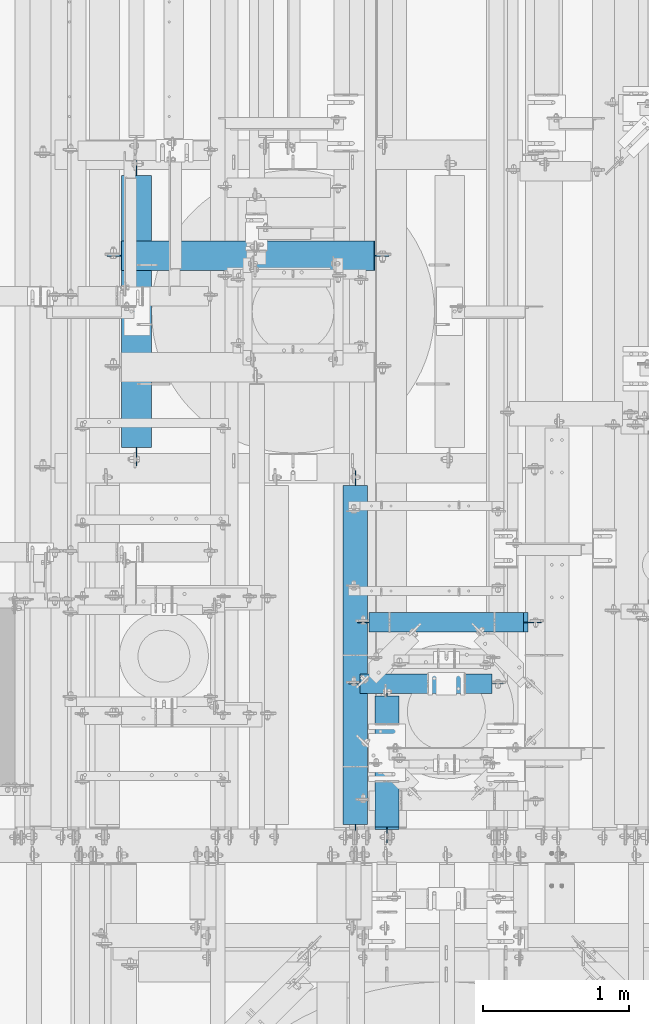
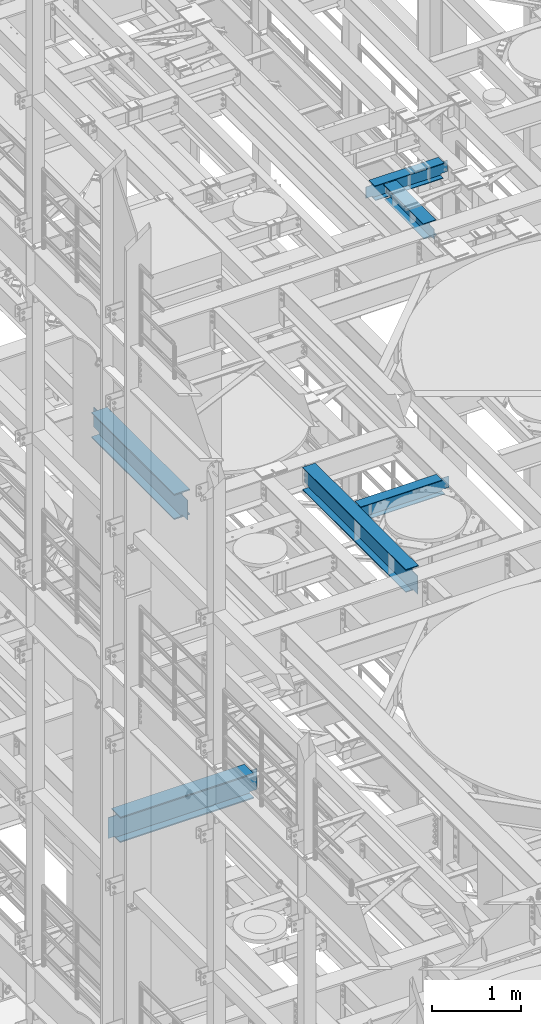
# One storey, part 1026 of 1876: 6 beams, 6 elements without a shape of their own.
"""IFC2X3 building model written with IfcOpenShell, lengths in millimetres."""

from ifc_helpers import new_model, si_unit, frame, origin_with_axes, place, context, subcontext, project, spatial, faceted_brep, material, type_object, element, aggregate, save


model = new_model("IFC2X3")

# Units and contexts
model_context = context("Model", 3, precision=1e-05, world=origin_with_axes())
body_context = subcontext(model_context, "Body", "Model", "MODEL_VIEW")
ifc_project = project(units=[si_unit("LENGTHUNIT", "METRE", prefix="MILLI"), si_unit("AREAUNIT", "SQUARE_METRE"), si_unit("VOLUMEUNIT", "CUBIC_METRE"), si_unit("MASSUNIT", "GRAM", prefix="KILO"), si_unit("TIMEUNIT", "SECOND"), si_unit("PLANEANGLEUNIT", "RADIAN"), si_unit("SOLIDANGLEUNIT", "STERADIAN"), si_unit("THERMODYNAMICTEMPERATUREUNIT", "DEGREE_CELSIUS"), si_unit("LUMINOUSINTENSITYUNIT", "LUMEN")], contexts=[model_context])

# Site, building, storey
site_placement = place(None, origin_with_axes())
site = spatial("IfcSite", under=ifc_project, at=site_placement, CompositionType="ELEMENT")
building_placement = place(site_placement, origin_with_axes())
building = spatial("IfcBuilding", under=site, at=building_placement, Name="Undefined", CompositionType="ELEMENT")
storey_placement = place(building_placement, origin_with_axes())
storey = spatial("IfcBuildingStorey", under=building, at=storey_placement, Name="Undefined", CompositionType="ELEMENT", Elevation=0.0)

# Assembly, beam
assembly_1_placement = place(storey_placement, origin_with_axes())
assembly_1 = element("IfcElementAssembly", 1, at=assembly_1_placement, inside=storey, Name="BEAM", AssemblyPlace="NOTDEFINED", PredefinedType="RIGID_FRAME")
ifc_material = material(Name="STEEL/A992")
beam_type_1 = type_object("IfcBeamType", Name="W8X24", PredefinedType="NOTDEFINED")
beam_1_placement = place(assembly_1_placement, frame((4013.20017785198, 1524.0, 17883.1875), z_axis=(0.0, 0.0, 1.0), x_axis=(0.0, 1.0, 0.0)))
beam_1 = element("IfcBeam", 2, at=beam_1_placement, type_object=beam_type_1, material=ifc_material, Name="BEAM", ObjectType="W8X24", context=body_context, shape_type="Brep", body=[
    faceted_brep([(1000.1244140625, -3.17500000000018, -90.4874999999993), (1000.1244140625, -82.5500000000002, -90.4874999820859), (1000.1244140625, -82.5500000000002, -100.012500000001), (1000.1244140625, 82.5500000000002, -100.012500000001), (1000.1244140625, 82.5500000000002, -90.4874999999993), (1000.1244140625, 3.17500000000018, -90.4874999999993), (1000.1244140625, 3.17500000000018, -87.3124998092644), (1000.1244140625, -3.17500000000018, -87.3124998092644), (1001.09114398509, 3.17500000000018, -82.452420291218), (1001.09114398509, -3.17500000000018, -82.452420291218), (1003.84415788557, 3.17500000000018, -78.3322438230643), (1003.84415788557, -3.17500000000018, -78.3322438230643), (1007.96433435372, 3.17500000000018, -75.5792299225868), (1007.96433435372, -3.17500000000018, -75.5792299225868), (1012.82441387176, 3.17500000000018, -74.6124999999993), (1012.82441387176, -3.17500000000018, -74.6124999999993), (1092.1994140625, -3.17500000000018, -74.6124999999993), (1092.1994140625, 3.17500000000018, -74.6124999999993), (127.79375, 82.5500000000002, 100.012500000001), (127.79375, -82.5500000000002, 100.012500000001), (1022.3494140625, -82.5500000000002, 100.012500000001), (1022.3494140625, 82.5500000000002, 100.012500000001), (127.79375, -82.5500000000002, 90.4874999999993), (1022.98096079099, -82.5500000000002, 90.4874999999993), (1022.3494140625, -82.5500000000002, 93.6624998092666), (1022.3494140625, 82.5500000000002, 93.6624998092666), (127.79375, 82.5500000000002, 90.4874999999993), (1022.98096079099, 82.5500000000002, 90.4874999999993), (127.79375, 3.17500000000018, 90.4874999999993), (1022.98096079099, 3.17500000000018, 90.4874999999993), (111.91875, -82.5500000000002, -90.4874998092637), (111.91875, -3.17500000000018, -90.4874999999993), (111.91875, 3.17500000000018, -90.4874999999993), (111.91875, 82.5500000000002, -90.4874999999993), (111.91875, 82.5500000000002, -100.012500000001), (111.91875, -82.5500000000002, -100.012500000001), (110.952020077412, -3.17500000000018, -85.6274202912173), (110.952020077412, 3.17500000000018, -85.6274202912173), (108.199006176934, -3.17500000000018, -81.5072438230636), (108.199006176934, 3.17500000000018, -81.5072438230636), (104.07882970878, -3.17500000000018, -78.7542299225861), (104.07882970878, 3.17500000000018, -78.7542299225861), (99.2187501907349, -3.17500000000018, -77.7874999999985), (99.2187501907349, 3.17500000000018, -77.7874999999985), (19.8437500000002, -3.17500000000018, -77.7874999999985), (19.8437500000002, 3.17500000000018, -77.7874999999985), (19.8437500000002, -3.17500000000018, 61.9125000000058), (19.8437500000002, 3.17500000000018, 61.9125000000058), (115.093750190735, -3.17500000000018, 61.9125000000058), (115.093750190735, 3.17500000000018, 61.9125000000058), (119.95382970878, -3.17500000000018, 62.8792299225934), (119.95382970878, 3.17500000000018, 62.8792299225934), (124.074006176934, -3.17500000000018, 65.6322438230709), (124.074006176934, 3.17500000000018, 65.6322438230709), (126.827020077412, -3.17500000000018, 69.7524202912246), (126.827020077412, 3.17500000000018, 69.7524202912246), (127.79375, -3.17500000000018, 74.612499809271), (127.79375, 3.17500000000018, 74.612499809271), (127.79375, -3.17500000000018, 90.4874999999993), (1022.98096079099, -3.17500000000018, 90.4874999999993), (1023.31614398509, -3.17500000000018, 88.8024202912202), (1023.31614398509, 3.17500000000018, 88.8024202912202), (1026.06915788557, -3.17500000000018, 84.6822438230665), (1026.06915788557, 3.17500000000018, 84.6822438230665), (1030.18933435372, -3.17500000000018, 81.929229922589), (1030.18933435372, 3.17500000000018, 81.929229922589), (1035.04941387176, -3.17500000000018, 80.9625000000015), (1035.04941387176, 3.17500000000018, 80.9625000000015), (1092.1994140625, -3.17500000000018, 80.9625000000015), (1092.1994140625, 3.17500000000018, 80.9625000000015)], [[[0, 1, 2, 3, 4, 5, 6, 7]], [[7, 6, 8, 9]], [[9, 8, 10, 11]], [[11, 10, 12, 13]], [[13, 12, 14, 15]], [[16, 15, 14, 17]], [[18, 19, 20, 21]], [[20, 19, 22, 23, 24]], [[20, 24, 25, 21]], [[26, 18, 21, 25, 27]], [[28, 26, 27, 29]], [[30, 31, 32, 33, 34, 35]], [[36, 37, 32, 31]], [[38, 39, 37, 36]], [[40, 41, 39, 38]], [[42, 43, 41, 40]], [[44, 45, 43, 42]], [[46, 47, 45, 44]], [[48, 49, 47, 46]], [[50, 51, 49, 48]], [[52, 53, 51, 50]], [[54, 55, 53, 52]], [[56, 57, 55, 54]], [[19, 18, 26, 28, 57, 56, 58, 22]], [[22, 58, 59, 23]], [[60, 61, 29, 27, 25, 24, 23, 59]], [[62, 63, 61, 60]], [[64, 65, 63, 62]], [[66, 67, 65, 64]], [[68, 69, 67, 66]], [[69, 68, 16, 17]], [[12, 10, 8, 6, 5, 32, 37, 39, 41, 43, 45, 47, 49, 51, 53, 55, 57, 28, 29, 61, 63, 65, 67, 69, 17, 14]], [[33, 32, 5, 4]], [[34, 33, 4, 3]], [[35, 34, 3, 2]], [[30, 35, 2, 1]], [[31, 30, 1, 0]], [[68, 66, 64, 62, 60, 59, 58, 56, 54, 52, 50, 48, 46, 44, 42, 40, 38, 36, 31, 0, 7, 9, 11, 13, 15, 16]]]),
])
aggregate(assembly_1, [beam_1])

assembly_2_placement = place(storey_placement, origin_with_axes())
assembly_2 = element("IfcElementAssembly", 3, at=assembly_2_placement, inside=storey, Name="BEAM", AssemblyPlace="NOTDEFINED", PredefinedType="RIGID_FRAME")
beam_type_2 = type_object("IfcBeamType", Name="W8X18", PredefinedType="NOTDEFINED")
beam_2_placement = place(assembly_2_placement, frame((3733.8, 2632.0744140625, 17880.0125), z_axis=(0.0, 0.0, 1.0), x_axis=(1.0, 0.0, 0.0)))
beam_2 = element("IfcBeam", 4, at=beam_2_placement, type_object=beam_type_2, material=ifc_material, Name="BEAM", ObjectType="W8X18", context=body_context, shape_type="Brep", body=[
    faceted_brep([(984.250000000001, -3.17500000000018, -95.25), (984.250000000001, -66.6750000000002, -95.25), (984.250000000001, -66.6750000000002, -103.1875), (984.250000000001, 66.6750000000002, -103.1875), (984.250000000001, 66.6750000000002, -95.25), (984.250000000001, 3.17500000000018, -95.25), (984.250000000001, 3.17500000000018, -90.4874998092637), (984.250000000001, -3.17500000000018, -90.4874998092637), (985.216729922588, 3.17500000000018, -85.6274202912173), (985.216729922588, -3.17500000000018, -85.6274202912173), (987.969743823067, 3.17500000000018, -81.5072438230636), (987.969743823067, -3.17500000000018, -81.5072438230636), (992.089920291221, 3.17500000000018, -78.7542299225861), (992.089920291221, -3.17500000000018, -78.7542299225861), (996.949999809266, 3.17500000000018, -77.7874999999985), (996.949999809266, -3.17500000000018, -77.7874999999985), (1076.325, -3.17500000000018, -77.7874999999985), (1076.325, 3.17500000000018, -77.7874999999985), (95.25, 3.17500000000018, 95.25), (95.25, 66.6750000000002, 95.25), (996.950000000001, 66.6750000000002, 95.25), (996.950000000001, 3.17500000000018, 95.25), (107.950000000001, -3.17500000000018, -90.48749980926), (107.950000000001, 3.17500000000018, -90.48749980926), (107.950000000001, 3.17500000000018, -95.25), (107.950000000001, 66.6750000000002, -95.25), (107.950000000001, 66.6750000000002, -103.1875), (107.950000000001, -66.6750000000002, -103.1875), (107.950000000001, -66.6750000000002, -95.25), (107.950000000001, -3.17500000000018, -95.25), (106.983270077413, -3.17500000000018, -85.6274202912136), (106.983270077413, 3.17500000000018, -85.6274202912136), (104.230256176935, -3.17500000000018, -81.50724382306), (104.230256176935, 3.17500000000018, -81.50724382306), (100.110079708781, -3.17500000000018, -78.7542299225825), (100.110079708781, 3.17500000000018, -78.7542299225825), (95.2500001907356, -3.17500000000018, -77.7874999999949), (95.2500001907356, 3.17500000000018, -77.7874999999949), (15.875, -3.17500000000018, -77.7874999999949), (15.875, 3.17500000000018, -77.7874999999949), (15.875, -3.17500000000018, 77.7874999999949), (15.875, 3.17500000000018, 77.7874999999949), (82.5500001907349, -3.17500000000018, 77.7874999999949), (82.5500001907349, 3.17500000000018, 77.7874999999949), (87.4100797087804, -3.17500000000018, 78.7542299225825), (87.4100797087804, 3.17500000000018, 78.7542299225825), (91.530256176934, -3.17500000000018, 81.50724382306), (91.530256176934, 3.17500000000018, 81.50724382306), (94.2832700774125, -3.17500000000018, 85.6274202912136), (94.2832700774125, 3.17500000000018, 85.6274202912136), (95.25, -3.17500000000018, 90.48749980926), (95.25, 3.17500000000018, 90.48749980926), (95.25, -66.6750000000002, 103.1875), (95.25, 66.6750000000002, 103.1875), (95.25, -3.17500000000018, 95.25), (95.25, -66.6750000000002, 95.25), (996.950000000001, -3.17500000000018, 95.25), (996.950000000001, -66.6750000000002, 95.25), (996.950000000001, -66.6750000000002, 103.1875), (996.950000000001, 66.6750000000002, 103.1875), (996.950000000001, -3.17500000000018, 90.4874998092637), (996.950000000001, 3.17500000000018, 90.4874998092637), (997.916729922588, -3.17500000000018, 85.6274202912173), (997.916729922588, 3.17500000000018, 85.6274202912173), (1000.66974382307, -3.17500000000018, 81.5072438230636), (1000.66974382307, 3.17500000000018, 81.5072438230636), (1004.78992029122, -3.17500000000018, 78.7542299225861), (1004.78992029122, 3.17500000000018, 78.7542299225861), (1009.64999980927, -3.17500000000018, 77.7874999999985), (1009.64999980927, 3.17500000000018, 77.7874999999985), (1076.325, -3.17500000000018, 77.7874999999985), (1076.325, 3.17500000000018, 77.7874999999985)], [[[0, 1, 2, 3, 4, 5, 6, 7]], [[7, 6, 8, 9]], [[9, 8, 10, 11]], [[11, 10, 12, 13]], [[13, 12, 14, 15]], [[16, 15, 14, 17]], [[18, 19, 20, 21]], [[22, 23, 24, 25, 26, 27, 28, 29]], [[30, 31, 23, 22]], [[32, 33, 31, 30]], [[34, 35, 33, 32]], [[36, 37, 35, 34]], [[38, 39, 37, 36]], [[40, 41, 39, 38]], [[42, 43, 41, 40]], [[44, 45, 43, 42]], [[46, 47, 45, 44]], [[48, 49, 47, 46]], [[50, 51, 49, 48]], [[52, 53, 19, 18, 51, 50, 54, 55]], [[55, 54, 56, 57]], [[52, 55, 57, 58]], [[53, 52, 58, 59]], [[19, 53, 59, 20]], [[58, 57, 56, 60, 61, 21, 20, 59]], [[62, 63, 61, 60]], [[64, 65, 63, 62]], [[66, 67, 65, 64]], [[68, 69, 67, 66]], [[70, 71, 69, 68]], [[71, 70, 16, 17]], [[12, 10, 8, 6, 5, 24, 23, 31, 33, 35, 37, 39, 41, 43, 45, 47, 49, 51, 18, 21, 61, 63, 65, 67, 69, 71, 17, 14]], [[25, 24, 5, 4]], [[26, 25, 4, 3]], [[27, 26, 3, 2]], [[28, 27, 2, 1]], [[29, 28, 1, 0]], [[70, 68, 66, 64, 62, 60, 56, 54, 50, 48, 46, 44, 42, 40, 38, 36, 34, 32, 30, 22, 29, 0, 7, 9, 11, 13, 15, 16]]]),
])
aggregate(assembly_2, [beam_2])

assembly_3_placement = place(storey_placement, origin_with_axes())
assembly_3 = element("IfcElementAssembly", 5, at=assembly_3_placement, inside=storey, Name="BEAM", AssemblyPlace="NOTDEFINED", PredefinedType="RIGID_FRAME")
beam_3_placement = place(assembly_3_placement, frame((3892.55, 3051.175, 13206.4125), z_axis=(0.0, 0.0, 1.0), x_axis=(1.0, 0.0, 0.0)))
beam_3 = element("IfcBeam", 6, at=beam_3_placement, type_object=beam_type_2, material=ifc_material, Name="BEAM", ObjectType="W8X18", context=body_context, shape_type="Brep", body=[
    faceted_brep([(-79.3750000000005, -3.17500000000018, -77.7875000000004), (-79.3750000000005, 3.17500000000018, -77.7875000000004), (-3.17499980926459, 3.17500000000018, -77.7875000000004), (-3.17499980926459, -3.17500000000018, -77.7875000000004), (1.6850797087809, 3.17500000000018, -78.7542299225879), (1.6850797087809, -3.17500000000018, -78.7542299225879), (5.80525617693456, 3.17500000000018, -81.5072438230654), (5.80525617693456, -3.17500000000018, -81.5072438230654), (8.55827007741254, 3.17500000000018, -85.6274202912191), (8.55827007741254, -3.17500000000018, -85.6274202912191), (9.52500000000055, -3.17500000000018, -90.4874998092655), (9.52500000000055, 3.17500000000018, -90.4874998092655), (9.52500000000055, 3.17500000000018, -95.25), (9.52500000000055, 66.6750000000002, -95.25), (9.52500000000055, 66.6750000000002, -103.1875), (9.52500000000055, -66.6750000000002, -103.1875), (9.52500000000055, -66.6750000000002, -95.25), (9.52500000000055, -3.17500000000018, -95.25), (4.54747350886464e-13, 3.17500000000018, 95.25), (4.54747350886464e-13, 66.6750000000002, 95.25), (1054.89375, 66.6750000000002, 95.25), (1054.89375, 3.17500000000018, 95.25), (-12.6999998092647, -3.17500000000018, 77.7875000000004), (-12.6999998092647, 3.17500000000018, 77.7875000000004), (-79.3750000000005, 3.17500000000018, 77.7875000000004), (-79.3750000000005, -3.17500000000018, 77.7875000000004), (-7.83992029121919, -3.17500000000018, 78.7542299225879), (-7.83992029121919, 3.17500000000018, 78.7542299225879), (-3.71974382306553, -3.17500000000018, 81.5072438230654), (-3.71974382306553, 3.17500000000018, 81.5072438230654), (-0.966729922587547, -3.17500000000018, 85.6274202912191), (-0.966729922587547, 3.17500000000018, 85.6274202912191), (4.54747350886464e-13, -3.17500000000018, 90.4874998092655), (4.54747350886464e-13, 3.17500000000018, 90.4874998092655), (4.54747350886464e-13, -66.6750000000002, 103.1875), (4.54747350886464e-13, 66.6750000000002, 103.1875), (4.54747350886464e-13, -3.17500000000018, 95.25), (4.54747350886464e-13, -66.6750000000002, 95.25), (1054.89375, -3.17500000000018, 95.25), (1054.89375, -66.6750000000002, 95.25), (1054.89375, -66.6750000000002, 103.1875), (1054.89375, 66.6750000000002, 103.1875), (1054.89375, -3.17500000000018, 90.4874998092637), (1054.89375, 3.17500000000018, 90.4874998092637), (1055.86047992259, -3.17500000000018, 85.6274202912173), (1055.86047992259, 3.17500000000018, 85.6274202912173), (1058.61349382307, -3.17500000000018, 81.5072438230636), (1058.61349382307, 3.17500000000018, 81.5072438230636), (1062.73367029122, -3.17500000000018, 78.7542299225861), (1062.73367029122, 3.17500000000018, 78.7542299225861), (1067.59374980927, -3.17500000000018, 77.7874999999985), (1067.59374980927, 3.17500000000018, 77.7874999999985), (1175.54375, -3.17500000000018, 77.7874999999985), (1175.54375, 3.17500000000018, 77.7874999999985), (1175.54375, -3.17500000000018, -77.7875000000022), (1175.54375, 3.17500000000018, -77.7875000000022), (1099.34374980927, -3.17500000000018, -77.7875000000022), (1099.34374980927, 3.17500000000018, -77.7875000000022), (1094.48367029122, -3.17500000000018, -78.7542299225897), (1094.48367029122, 3.17500000000018, -78.7542299225897), (1090.36349382307, -3.17500000000018, -81.5072438230673), (1090.36349382307, 3.17500000000018, -81.5072438230673), (1087.61047992259, -3.17500000000018, -85.6274202912209), (1087.61047992259, 3.17500000000018, -85.6274202912209), (1086.64375, -3.17500000000018, -90.4874998092673), (1086.64375, 3.17500000000018, -90.4874998092673), (1086.64375, -3.17500000000018, -95.25), (1086.64375, -66.6750000000002, -95.25), (1086.64375, -66.6750000000002, -103.1875), (1086.64375, 66.6750000000002, -103.1875), (1086.64375, 66.6750000000002, -95.25), (1086.64375, 3.17500000000018, -95.25)], [[[0, 1, 2, 3]], [[3, 2, 4, 5]], [[5, 4, 6, 7]], [[7, 6, 8, 9]], [[10, 11, 12, 13, 14, 15, 16, 17]], [[9, 8, 11, 10]], [[18, 19, 20, 21]], [[22, 23, 24, 25]], [[26, 27, 23, 22]], [[28, 29, 27, 26]], [[30, 31, 29, 28]], [[32, 33, 31, 30]], [[34, 35, 19, 18, 33, 32, 36, 37]], [[37, 36, 38, 39]], [[34, 37, 39, 40]], [[35, 34, 40, 41]], [[19, 35, 41, 20]], [[40, 39, 38, 42, 43, 21, 20, 41]], [[44, 45, 43, 42]], [[46, 47, 45, 44]], [[48, 49, 47, 46]], [[50, 51, 49, 48]], [[52, 53, 51, 50]], [[53, 52, 54, 55]], [[54, 56, 57, 55]], [[58, 59, 57, 56]], [[60, 61, 59, 58]], [[62, 63, 61, 60]], [[64, 65, 63, 62]], [[66, 67, 68, 69, 70, 71, 65, 64]], [[67, 66, 17, 16]], [[68, 67, 16, 15]], [[69, 68, 15, 14]], [[70, 69, 14, 13]], [[71, 70, 13, 12]], [[6, 4, 2, 1, 24, 23, 27, 29, 31, 33, 18, 21, 43, 45, 47, 49, 51, 53, 55, 57, 59, 61, 63, 65, 71, 12, 11, 8]], [[25, 24, 1, 0]], [[66, 64, 62, 60, 58, 56, 54, 52, 50, 48, 46, 44, 42, 38, 36, 32, 30, 28, 26, 22, 25, 0, 3, 5, 7, 9, 10, 17]]]),
])
aggregate(assembly_3, [beam_3])

assembly_4_placement = place(storey_placement, origin_with_axes())
assembly_4 = element("IfcElementAssembly", 7, at=assembly_4_placement, inside=storey, Name="BEAM", AssemblyPlace="NOTDEFINED", PredefinedType="RIGID_FRAME")
beam_type_3 = type_object("IfcBeamType", Name="W12X30", PredefinedType="NOTDEFINED")
beam_4_placement = place(assembly_4_placement, frame((3797.3, 1524.0, 13152.4375), z_axis=(0.0, 0.0, 1.0), x_axis=(0.0, 1.0, 0.0)))
beam_4 = element("IfcBeam", 8, at=beam_4_placement, type_object=beam_type_3, material=ifc_material, Name="BEAM", ObjectType="W12X30", context=body_context, shape_type="Brep", body=[
    faceted_brep([(19.8437500000002, -3.17500000000018, -131.762499999993), (19.8437500000002, 3.17500000000018, -131.762499999993), (134.143750190735, 3.17500000000018, -131.762500000001), (134.143750190735, -3.17500000000018, -131.762500000001), (139.00382970878, 3.17500000000018, -132.729229922588), (139.00382970878, -3.17500000000018, -132.729229922588), (143.124006176934, 3.17500000000018, -135.482243823066), (143.124006176934, -3.17500000000018, -135.482243823066), (145.877020077412, 3.17500000000018, -139.602420291219), (145.877020077412, -3.17500000000018, -139.602420291219), (146.84375, -3.17500000000018, -144.462499809266), (146.84375, 3.17500000000018, -144.462499809266), (146.84375, 3.17500000000018, -146.049999999999), (146.84375, 82.5500000000002, -146.049999999999), (146.84375, 82.5500000000002, -157.1625), (146.84375, -82.5500000000002, -157.1625), (146.84375, -82.5500000000002, -146.049999999999), (146.84375, -3.17500000000018, -146.049999999999), (2461.41875, 82.5500000000002, 146.049999999999), (2461.41875, 3.17500000000018, 146.049999999999), (146.84375, 3.17500000000018, 146.049999999999), (146.84375, 82.5500000000002, 146.049999999999), (134.143750190735, -3.17500000000018, 119.0625), (134.143750190735, 3.17500000000018, 119.0625), (19.8437491105051, 3.17499999999995, 119.062500000004), (19.8437491105051, -3.17499999999995, 119.062500000004), (139.00382970878, -3.17500000000018, 120.029229922588), (139.00382970878, 3.17500000000018, 120.029229922588), (143.124006176934, -3.17500000000018, 122.782243823065), (143.124006176934, 3.17500000000018, 122.782243823065), (145.877020077412, -3.17500000000018, 126.902420291219), (145.877020077412, 3.17500000000018, 126.902420291219), (146.84375, -3.17500000000018, 131.762499809265), (146.84375, 3.17500000000018, 131.762499809265), (2461.41875, -82.5500000000002, 157.1625), (2461.41875, 82.5500000000002, 157.1625), (146.84375, 82.5500000000002, 157.1625), (146.84375, -82.5500000000002, 157.1625), (2461.41875, -82.5500000000002, 146.049999999999), (146.84375, -82.5500000000002, 146.049999999999), (2461.41875, -3.17500000000018, 146.049999999999), (146.84375, -3.17500000000018, 146.049999999999), (2461.41875, -3.17500000000018, 131.762499809265), (2461.41875, 3.17500000000018, 131.762499809265), (2462.38547992259, -3.17500000000018, 126.902420291219), (2462.38547992259, 3.17500000000018, 126.902420291219), (2465.13849382307, -3.17500000000018, 122.782243823065), (2465.13849382307, 3.17500000000018, 122.782243823065), (2469.25867029122, -3.17500000000018, 120.029229922588), (2469.25867029122, 3.17500000000018, 120.029229922588), (2474.11874980927, -3.17500000000018, 119.0625), (2474.11874980927, 3.17500000000018, 119.0625), (2563.01875, -3.17500000000018, 119.0625), (2563.01875, 3.17500000000018, 119.0625), (2563.01875, -3.17500000000018, -131.762500000001), (2563.01875, 3.17500000000018, -131.762500000001), (2474.11874980927, -3.17500000000018, -131.762500000001), (2474.11874980927, 3.17500000000018, -131.762500000001), (2469.25867029122, -3.17500000000018, -132.729229922588), (2469.25867029122, 3.17500000000018, -132.729229922588), (2465.13849382307, -3.17500000000018, -135.482243823066), (2465.13849382307, 3.17500000000018, -135.482243823066), (2462.38547992259, -3.17500000000018, -139.602420291219), (2462.38547992259, 3.17500000000018, -139.602420291219), (2461.41875, -3.17500000000018, -144.462499809266), (2461.41875, 3.17500000000018, -144.462499809266), (2461.41875, -3.17500000000018, -146.049999999999), (2461.41875, -82.5500000000002, -146.049999999999), (2461.41875, -82.5500000000002, -157.1625), (2461.41875, 82.5500000000002, -157.1625), (2461.41875, 82.5500000000002, -146.049999999999), (2461.41875, 3.17500000000018, -146.049999999999)], [[[0, 1, 2, 3]], [[3, 2, 4, 5]], [[5, 4, 6, 7]], [[7, 6, 8, 9]], [[10, 11, 12, 13, 14, 15, 16, 17]], [[9, 8, 11, 10]], [[18, 19, 20, 21]], [[22, 23, 24, 25]], [[26, 27, 23, 22]], [[28, 29, 27, 26]], [[30, 31, 29, 28]], [[32, 33, 31, 30]], [[34, 35, 36, 37]], [[38, 34, 37, 39]], [[40, 38, 39, 41]], [[37, 36, 21, 20, 33, 32, 41, 39]], [[35, 18, 21, 36]], [[34, 38, 40, 42, 43, 19, 18, 35]], [[44, 45, 43, 42]], [[46, 47, 45, 44]], [[48, 49, 47, 46]], [[50, 51, 49, 48]], [[52, 53, 51, 50]], [[53, 52, 54, 55]], [[54, 56, 57, 55]], [[58, 59, 57, 56]], [[60, 61, 59, 58]], [[62, 63, 61, 60]], [[64, 65, 63, 62]], [[66, 67, 68, 69, 70, 71, 65, 64]], [[67, 66, 17, 16]], [[68, 67, 16, 15]], [[69, 68, 15, 14]], [[70, 69, 14, 13]], [[71, 70, 13, 12]], [[6, 4, 2, 1, 24, 23, 27, 29, 31, 33, 20, 19, 43, 45, 47, 49, 51, 53, 55, 57, 59, 61, 63, 65, 71, 12, 11, 8]], [[25, 24, 1, 0]], [[66, 64, 62, 60, 58, 56, 54, 52, 50, 48, 46, 44, 42, 40, 41, 32, 30, 28, 26, 22, 25, 0, 3, 5, 7, 9, 10, 17]]]),
])
aggregate(assembly_4, [beam_4])

assembly_5_placement = place(storey_placement, origin_with_axes())
assembly_5 = element("IfcElementAssembly", 9, at=assembly_5_placement, inside=storey, Name="BEAM", AssemblyPlace="NOTDEFINED", PredefinedType="RIGID_FRAME")
beam_type_4 = type_object("IfcBeamType", Name="W14X48", PredefinedType="NOTDEFINED")
beam_5_placement = place(assembly_5_placement, frame((2301.875, 4057.65, 13134.975), z_axis=(0.0, 0.0, 1.0), x_axis=(0.0, 1.0, 0.0)))
beam_5 = element("IfcBeam", 10, at=beam_5_placement, type_object=beam_type_4, material=ifc_material, Name="BEAM", ObjectType="W14X48", context=body_context, shape_type="Brep", body=[
    faceted_brep([(62.7062500000002, -3.96875, -136.525), (62.7062500000002, 3.96875, -136.525), (177.006250190735, 3.96875, -136.525), (177.006250190735, -3.96875, -136.525), (181.866329708781, 3.96875, -137.491729922587), (181.866329708781, -3.96875, -137.491729922587), (185.986506176934, 3.96875, -140.244743823065), (185.986506176934, -3.96875, -140.244743823065), (188.739520077413, 3.96875, -144.364920291218), (188.739520077413, -3.96875, -144.364920291218), (189.70625, -3.96875, -149.224999809265), (189.70625, 3.96875, -149.224999809265), (189.70625, 3.96875, -158.75), (189.70625, 101.6, -158.75), (189.70625, 101.6, -174.625), (189.70625, -101.6, -174.625), (189.70625, -101.6, -158.75), (189.70625, -3.96875, -158.75), (189.70625, 3.96875, 158.75), (189.70625, 101.6, 158.75), (2045.49375, 101.6, 158.75), (2045.49375, 3.96875, 158.75), (177.006250190735, -3.96875, 136.525), (177.006250190735, 3.96875, 136.525), (62.7062500000002, 3.96875, 136.525), (62.7062500000002, -3.96875, 136.525), (181.866329708781, -3.96875, 137.491729922587), (181.866329708781, 3.96875, 137.491729922587), (185.986506176934, -3.96875, 140.244743823065), (185.986506176934, 3.96875, 140.244743823065), (188.739520077413, -3.96875, 144.364920291218), (188.739520077413, 3.96875, 144.364920291218), (189.70625, -3.96875, 149.224999809265), (189.70625, 3.96875, 149.224999809265), (189.70625, 101.6, 174.625), (189.70625, -101.6, 174.625), (2045.49375, -101.6, 174.625), (2045.49375, 101.6, 174.625), (189.70625, -101.6, 158.75), (2045.49375, -101.6, 158.75), (189.70625, -3.96875, 158.75), (2045.49375, -3.96875, 158.75), (2045.49375, -3.96875, 149.224999809265), (2045.49375, 3.96875, 149.224999809265), (2046.46047992259, -3.96875, 144.364920291218), (2046.46047992259, 3.96875, 144.364920291218), (2049.21349382307, -3.96875, 140.244743823065), (2049.21349382307, 3.96875, 140.244743823065), (2053.33367029122, -3.96875, 137.491729922587), (2053.33367029122, 3.96875, 137.491729922587), (2058.19374980927, -3.96875, 136.525), (2058.19374980927, 3.96875, 136.525), (2172.49375, -3.96875, 136.525), (2172.49375, 3.96875, 136.525), (2172.49375, -3.96875, -136.525), (2172.49375, 3.96875, -136.525), (2058.19374980927, -3.96875, -136.525), (2058.19374980927, 3.96875, -136.525), (2053.33367029122, -3.96875, -137.491729922587), (2053.33367029122, 3.96875, -137.491729922587), (2049.21349382307, -3.96875, -140.244743823065), (2049.21349382307, 3.96875, -140.244743823065), (2046.46047992259, -3.96875, -144.364920291218), (2046.46047992259, 3.96875, -144.364920291218), (2045.49375, -3.96875, -149.224999809265), (2045.49375, 3.96875, -149.224999809265), (2045.49375, -3.96875, -158.75), (2045.49375, -101.6, -158.75), (2045.49375, -101.6, -174.625), (2045.49375, 101.6, -174.625), (2045.49375, 101.6, -158.75), (2045.49375, 3.96875, -158.75)], [[[0, 1, 2, 3]], [[3, 2, 4, 5]], [[5, 4, 6, 7]], [[7, 6, 8, 9]], [[10, 11, 12, 13, 14, 15, 16, 17]], [[9, 8, 11, 10]], [[18, 19, 20, 21]], [[22, 23, 24, 25]], [[26, 27, 23, 22]], [[28, 29, 27, 26]], [[30, 31, 29, 28]], [[32, 33, 31, 30]], [[34, 35, 36, 37]], [[35, 38, 39, 36]], [[38, 40, 41, 39]], [[35, 34, 19, 18, 33, 32, 40, 38]], [[19, 34, 37, 20]], [[36, 39, 41, 42, 43, 21, 20, 37]], [[44, 45, 43, 42]], [[46, 47, 45, 44]], [[48, 49, 47, 46]], [[50, 51, 49, 48]], [[52, 53, 51, 50]], [[53, 52, 54, 55]], [[54, 56, 57, 55]], [[58, 59, 57, 56]], [[60, 61, 59, 58]], [[62, 63, 61, 60]], [[64, 65, 63, 62]], [[66, 67, 68, 69, 70, 71, 65, 64]], [[17, 16, 67, 66]], [[16, 15, 68, 67]], [[15, 14, 69, 68]], [[14, 13, 70, 69]], [[13, 12, 71, 70]], [[59, 61, 63, 65, 71, 12, 11, 8, 6, 4, 2, 1, 24, 23, 27, 29, 31, 33, 18, 21, 43, 45, 47, 49, 51, 53, 55, 57]], [[25, 24, 1, 0]], [[52, 50, 48, 46, 44, 42, 41, 40, 32, 30, 28, 26, 22, 25, 0, 3, 5, 7, 9, 10, 17, 66, 64, 62, 60, 58, 56, 54]]]),
])
aggregate(assembly_5, [beam_5])

assembly_6_placement = place(storey_placement, origin_with_axes())
assembly_6 = element("IfcElementAssembly", 11, at=assembly_6_placement, inside=storey, Name="BEAM", AssemblyPlace="NOTDEFINED", PredefinedType="RIGID_FRAME")
beam_6_placement = place(assembly_6_placement, frame((2089.15, 5556.25, 7978.775), z_axis=(0.0, 0.0, 1.0), x_axis=(1.0, 0.0, 0.0)))
beam_6 = element("IfcBeam", 12, at=beam_6_placement, type_object=beam_type_4, material=ifc_material, Name="BEAM", ObjectType="W14X48", context=body_context, shape_type="Brep", body=[
    faceted_brep([(10.3187500000004, -3.96875, -142.875), (10.3187500000004, 3.96875, -142.875), (92.8687501907352, 3.96875, -142.875), (92.8687501907352, -3.96875, -142.875), (97.7288297087807, 3.96875, -143.841729922588), (97.7288297087807, -3.96875, -143.841729922588), (101.849006176934, 3.96875, -146.594743823066), (101.849006176934, -3.96875, -146.594743823066), (104.602020077412, 3.96875, -150.71492029122), (104.602020077412, -3.96875, -150.71492029122), (105.56875, -3.96875, -155.574999809265), (105.56875, 3.96875, -155.574999809265), (105.56875, 3.96875, -158.75), (105.56875, 101.6, -158.75), (105.56875, 101.6, -174.625), (105.56875, -101.6, -174.625), (105.56875, -101.6, -158.75), (105.56875, -3.96875, -158.75), (1837.53087964162, 101.6, 158.75), (1837.53087964162, 3.96875, 158.75), (111.91875, 3.96875, 158.75), (111.91875, 101.6, 158.75), (99.2187501907351, -3.96875, 142.875), (99.2187501907351, 3.96875, 142.875), (10.3187500000004, 3.96875, 142.875), (10.3187500000004, -3.96875, 142.875), (104.078829708781, -3.96875, 143.841729922588), (104.078829708781, 3.96875, 143.841729922588), (108.199006176934, -3.96875, 146.594743823066), (108.199006176934, 3.96875, 146.594743823066), (110.952020077412, -3.96875, 150.71492029122), (110.952020077412, 3.96875, 150.71492029122), (111.91875, -3.96875, 155.574999809265), (111.91875, 3.96875, 155.574999809265), (1837.53087964162, -101.6, 174.625), (1837.53087964162, 101.6, 174.625), (111.91875, 101.6, 174.625), (111.91875, -101.6, 174.625), (1837.53087964162, -101.6, 158.75), (111.91875, -101.6, 158.75), (1837.53087964162, -3.96875, 158.75), (111.91875, -3.96875, 158.75), (1837.53087964162, -3.96875, 155.574999809265), (1837.53087964162, 3.96875, 155.574999809265), (1838.4976095642, -3.96875, 150.71492029122), (1838.4976095642, 3.96875, 150.71492029122), (1841.25062346468, -3.96875, 146.594743823066), (1841.25062346468, 3.96875, 146.594743823066), (1845.37079993284, -3.96875, 143.841729922588), (1845.37079993284, 3.96875, 143.841729922588), (1850.23087945088, -3.96875, 142.875), (1850.23087945088, 3.96875, 142.875), (1939.13087964162, -3.96875, 142.875), (1939.13087964162, 3.96875, 142.875), (1939.13087964162, -3.96875, -142.875), (1939.13087964162, 3.96875, -142.875), (1856.58087945088, -3.96875, -142.875), (1856.58087945088, 3.96875, -142.875), (1851.72079993284, -3.96875, -143.841729922588), (1851.72079993284, 3.96875, -143.841729922588), (1847.60062346468, -3.96875, -146.594743823066), (1847.60062346468, 3.96875, -146.594743823066), (1844.8476095642, -3.96875, -150.71492029122), (1844.8476095642, 3.96875, -150.71492029122), (1843.88087964162, -3.96875, -155.574999809265), (1843.88087964162, 3.96875, -155.574999809265), (1843.88087964162, -3.96875, -158.75), (1843.88087964162, -101.6, -158.75), (1843.88087964162, -101.6, -174.625), (1843.88087964162, 101.6, -174.625), (1843.88087964162, 101.6, -158.75), (1843.88087964162, 3.96875, -158.75)], [[[0, 1, 2, 3]], [[3, 2, 4, 5]], [[5, 4, 6, 7]], [[7, 6, 8, 9]], [[10, 11, 12, 13, 14, 15, 16, 17]], [[9, 8, 11, 10]], [[18, 19, 20, 21]], [[22, 23, 24, 25]], [[26, 27, 23, 22]], [[28, 29, 27, 26]], [[30, 31, 29, 28]], [[32, 33, 31, 30]], [[34, 35, 36, 37]], [[38, 34, 37, 39]], [[40, 38, 39, 41]], [[37, 36, 21, 20, 33, 32, 41, 39]], [[35, 18, 21, 36]], [[34, 38, 40, 42, 43, 19, 18, 35]], [[44, 45, 43, 42]], [[46, 47, 45, 44]], [[48, 49, 47, 46]], [[50, 51, 49, 48]], [[52, 53, 51, 50]], [[53, 52, 54, 55]], [[54, 56, 57, 55]], [[58, 59, 57, 56]], [[60, 61, 59, 58]], [[62, 63, 61, 60]], [[64, 65, 63, 62]], [[66, 67, 68, 69, 70, 71, 65, 64]], [[67, 66, 17, 16]], [[68, 67, 16, 15]], [[69, 68, 15, 14]], [[70, 69, 14, 13]], [[71, 70, 13, 12]], [[6, 4, 2, 1, 24, 23, 27, 29, 31, 33, 20, 19, 43, 45, 47, 49, 51, 53, 55, 57, 59, 61, 63, 65, 71, 12, 11, 8]], [[25, 24, 1, 0]], [[66, 64, 62, 60, 58, 56, 54, 52, 50, 48, 46, 44, 42, 40, 41, 32, 30, 28, 26, 22, 25, 0, 3, 5, 7, 9, 10, 17]]]),
])
aggregate(assembly_6, [beam_6])

save(model, "model.ifc")
